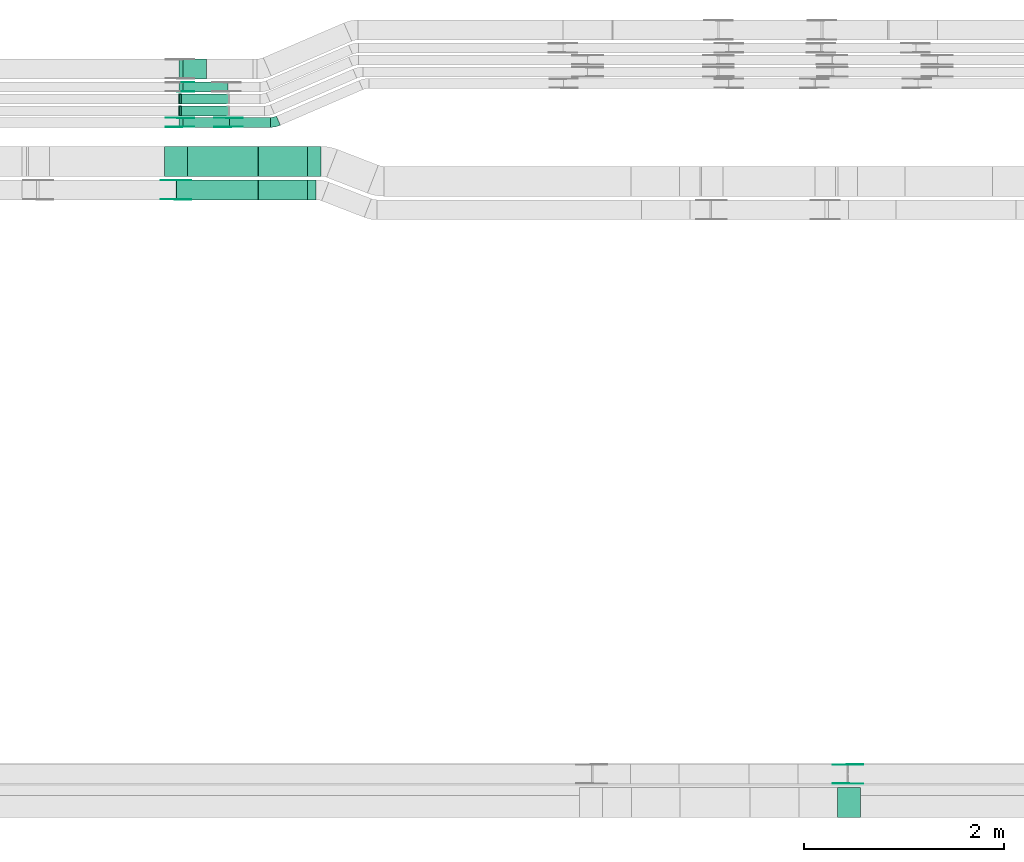
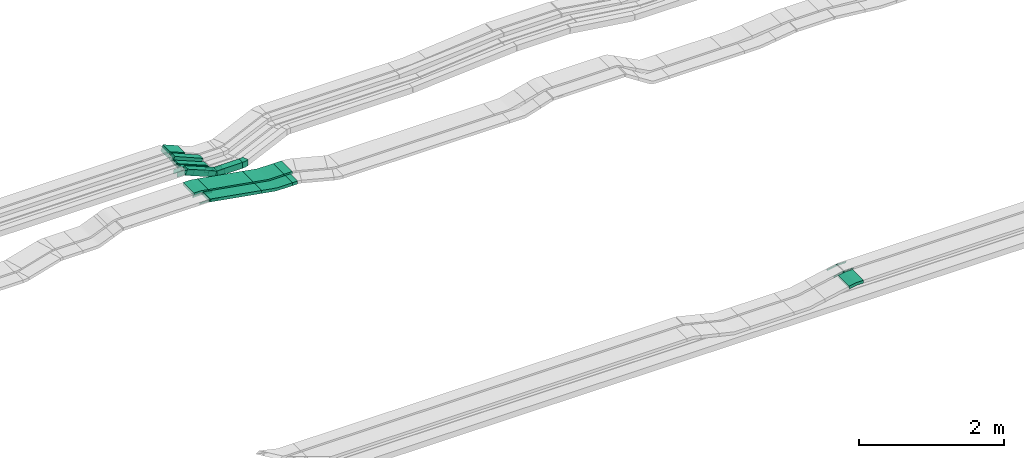
# One storey, part 15 of 28: 25 flow fittings, 10 flow segments.
"""IFC2X3 building model written with IfcOpenShell, lengths in millimetres."""

from ifc_helpers import new_model, entity, si_unit, converted_unit, derived_unit, direction, frame, frame_2d, origin, origin_2d_with_axis, place, context, subcontext, project, spatial, polyline, circle_curve, parameter, trimmed, segment, composite_curve, rectangle, outline, extrude, faceted_brep, source, transform, mapped, material, type_object, type_shapes, element, save


model = new_model("IFC2X3")

# Units and contexts
model_context = context("Model", 3, precision=0.01, world=origin(), true_north=direction((6.12303176911189e-17, 1.0)))
body_context = subcontext(model_context, "Body", "Model", "MODEL_VIEW")
ifc_project = project(units=[si_unit("LENGTHUNIT", "METRE", prefix="MILLI"), si_unit("AREAUNIT", "SQUARE_METRE"), si_unit("VOLUMEUNIT", "CUBIC_METRE"), converted_unit("PLANEANGLEUNIT", "DEGREE", entity("IfcRatioMeasure", 0.0174532925199433), si_unit("PLANEANGLEUNIT", "RADIAN"), dimensions=[0, 0, 0, 0, 0, 0, 0]), si_unit("MASSUNIT", "GRAM", prefix="KILO"), derived_unit("MASSDENSITYUNIT", [(si_unit("MASSUNIT", "GRAM", prefix="KILO"), 1), (si_unit("LENGTHUNIT", "METRE"), -3)]), derived_unit("MOMENTOFINERTIAUNIT", [(si_unit("LENGTHUNIT", "METRE"), 4)]), si_unit("TIMEUNIT", "SECOND"), si_unit("FREQUENCYUNIT", "HERTZ"), si_unit("THERMODYNAMICTEMPERATUREUNIT", "DEGREE_CELSIUS"), derived_unit("THERMALTRANSMITTANCEUNIT", [(si_unit("MASSUNIT", "GRAM", prefix="KILO"), 1), (si_unit("THERMODYNAMICTEMPERATUREUNIT", "KELVIN"), -1), (si_unit("TIMEUNIT", "SECOND"), -3)]), derived_unit("VOLUMETRICFLOWRATEUNIT", [(si_unit("LENGTHUNIT", "METRE"), 3), (si_unit("TIMEUNIT", "SECOND"), -1)]), derived_unit("MASSFLOWRATEUNIT", [(si_unit("MASSUNIT", "GRAM", prefix="KILO"), 1), (si_unit("TIMEUNIT", "SECOND"), -1)]), derived_unit("ROTATIONALFREQUENCYUNIT", [(si_unit("TIMEUNIT", "SECOND"), -1)]), si_unit("ELECTRICCURRENTUNIT", "AMPERE"), si_unit("ELECTRICVOLTAGEUNIT", "VOLT"), si_unit("POWERUNIT", "WATT"), si_unit("FORCEUNIT", "NEWTON", prefix="KILO"), si_unit("ILLUMINANCEUNIT", "LUX"), si_unit("LUMINOUSFLUXUNIT", "LUMEN"), si_unit("LUMINOUSINTENSITYUNIT", "CANDELA"), derived_unit("USERDEFINED", [(si_unit("MASSUNIT", "GRAM", prefix="KILO"), -1), (si_unit("LENGTHUNIT", "METRE"), -2), (si_unit("TIMEUNIT", "SECOND"), 3), (si_unit("LUMINOUSFLUXUNIT", "LUMEN"), 1)]), derived_unit("LINEARVELOCITYUNIT", [(si_unit("LENGTHUNIT", "METRE"), 1), (si_unit("TIMEUNIT", "SECOND"), -1)]), si_unit("PRESSUREUNIT", "PASCAL"), derived_unit("USERDEFINED", [(si_unit("LENGTHUNIT", "METRE"), -2), (si_unit("MASSUNIT", "GRAM", prefix="KILO"), 1), (si_unit("TIMEUNIT", "SECOND"), -2)]), derived_unit("LINEARFORCEUNIT", [(si_unit("MASSUNIT", "GRAM", prefix="KILO"), 1), (si_unit("LENGTHUNIT", "METRE"), 1), (si_unit("TIMEUNIT", "SECOND"), -2), (si_unit("LENGTHUNIT", "METRE"), -1)]), derived_unit("PLANARFORCEUNIT", [(si_unit("MASSUNIT", "GRAM", prefix="KILO"), 1), (si_unit("LENGTHUNIT", "METRE"), 1), (si_unit("TIMEUNIT", "SECOND"), -2), (si_unit("LENGTHUNIT", "METRE"), -2)])], contexts=[model_context])

# Site, building, storey
site_placement = place(None, origin())
site = spatial("IfcSite", under=ifc_project, at=site_placement, CompositionType="ELEMENT")
building_placement = place(site_placement, origin())
building = spatial("IfcBuilding", under=site, at=building_placement, CompositionType="ELEMENT")
storey_placement = place(building_placement, frame((0.0, 0.0, 15900.0)))
storey = spatial("IfcBuildingStorey", under=building, at=storey_placement, CompositionType="ELEMENT", Elevation=15900.0)

# Flow segments
cable_carrier_segment_type = type_object("IfcCableCarrierSegmentType", PredefinedType="CABLETRAYSEGMENT")
flow_segment_1_placement = place(storey_placement, frame((45693.95, 15124.99, 2634.95)))
element("IfcFlowSegment", 1, at=flow_segment_1_placement, inside=storey, type_object=cable_carrier_segment_type, context=body_context, shape_type="SweptSolid", body=[
    extrude(rectangle(XDim=406.031422459047, YDim=99.9999999999989, at=origin_2d_with_axis()), frame((203.02, 50.0, 0.0)), (0.0, 0.0, 1.0), 99.9999999999989),
])
flow_segment_2_placement = place(storey_placement, frame((45186.78, 15124.99, 2643.12)))
element("IfcFlowSegment", 2, at=flow_segment_2_placement, inside=storey, type_object=cable_carrier_segment_type, context=body_context, shape_type="SweptSolid", body=[
    extrude(rectangle(XDim=99.9999999999964, YDim=99.9999999999989, at=origin_2d_with_axis()), frame((18.98, 50.0, 237.42), z_axis=(0.92511308529448, 0.0, -0.37969168994979), x_axis=(0.37969168994979, 0.0, 0.92511308529448)), (0.0, 0.0, 1.0), 503.461377096309),
])
flow_segment_3_placement = place(storey_placement, frame((45191.31, 15239.46, 2642.86)))
element("IfcFlowSegment", 3, at=flow_segment_3_placement, inside=storey, type_object=cable_carrier_segment_type, context=body_context, shape_type="SweptSolid", body=[
    extrude(rectangle(XDim=50.0000000000019, YDim=99.9999999999989, at=origin_2d_with_axis()), frame((9.49, 50.0, 216.4), z_axis=(0.925113085294563, 0.0, -0.379691689949589), x_axis=(0.379691689949589, 0.0, 0.925113085294563)), (0.0, 0.0, 1.0), 509.012241763836),
])
flow_segment_4_placement = place(storey_placement, frame((45191.31, 15359.46, 2642.86)))
element("IfcFlowSegment", 4, at=flow_segment_4_placement, inside=storey, type_object=cable_carrier_segment_type, context=body_context, shape_type="SweptSolid", body=[
    extrude(rectangle(XDim=50.0000000000092, YDim=99.9999999999989, at=origin_2d_with_axis()), frame((9.49, 50.0, 216.4), z_axis=(0.925113085294515, 0.0, -0.379691689949707), x_axis=(0.379691689949707, 0.0, 0.925113085294515)), (0.0, 0.0, 1.0), 509.012241762945),
])
flow_segment_5_placement = place(storey_placement, frame((45186.49, 15479.99, 2643.67)))
element("IfcFlowSegment", 5, at=flow_segment_5_placement, inside=storey, type_object=cable_carrier_segment_type, context=body_context, shape_type="SweptSolid", body=[
    extrude(rectangle(XDim=99.9999999999968, YDim=99.9999999999989, at=origin_2d_with_axis()), frame((19.55, 50.0, 236.64), z_axis=(0.92041129975061, 0.0, -0.390951453880648), x_axis=(0.390951453880648, 0.0, 0.92041129975061)), (0.0, 0.0, 1.0), 487.586158263763),
])
flow_segment_6_placement = place(storey_placement, frame((45186.66, 15609.99, 2735.0)))
element("IfcFlowSegment", 6, at=flow_segment_6_placement, inside=storey, type_object=cable_carrier_segment_type, context=body_context, shape_type="SweptSolid", body=[
    extrude(rectangle(XDim=99.9999999999999, YDim=199.999999999998, at=origin_2d_with_axis()), frame((19.23, 100.0, 145.46), z_axis=(0.923076923076912, 0.0, -0.384615384615411), x_axis=(0.384615384615411, 0.0, 0.923076923076912)), (0.0, 0.0, 1.0), 258.199999999951),
])
flow_segment_7_placement = place(storey_placement, frame((46475.24, 14635.03, 2650.0)))
element("IfcFlowSegment", 7, at=flow_segment_7_placement, inside=storey, type_object=cable_carrier_segment_type, context=body_context, shape_type="SweptSolid", body=[
    extrude(rectangle(XDim=133.135877151261, YDim=300.000000000001, at=origin_2d_with_axis()), frame((66.57, 150.0, 0.0), z_axis=(0.0, 0.0, 1.0), x_axis=(-1.0, 0.0, 0.0)), (0.0, 0.0, 1.0), 50.0000000000016),
])
flow_segment_8_placement = place(storey_placement, frame((46475.24, 14400.03, 2650.0)))
element("IfcFlowSegment", 8, at=flow_segment_8_placement, inside=storey, type_object=cable_carrier_segment_type, context=body_context, shape_type="SweptSolid", body=[
    extrude(rectangle(XDim=82.4973887325516, YDim=200.000000000002, at=origin_2d_with_axis()), frame((41.25, 100.0, 0.0), z_axis=(0.0, 0.0, 1.0), x_axis=(-1.0, 0.0, 0.0)), (0.0, 0.0, 1.0), 50.0000000000038),
])
flow_segment_9_placement = place(storey_placement, frame((45154.32, 14400.03, 2692.89)))
element("IfcFlowSegment", 9, at=flow_segment_9_placement, inside=storey, type_object=cable_carrier_segment_type, context=body_context, shape_type="SweptSolid", body=[
    extrude(rectangle(XDim=49.9999999999991, YDim=199.999999999998, at=origin_2d_with_axis()), frame((4.26, 100.0, 166.52), z_axis=(0.985391054853274, 0.0, -0.170306984634076), x_axis=(0.170306984634076, 0.0, 0.985391054853274)), (0.0, 0.0, 1.0), 833.091034374861),
])
flow_segment_10_placement = place(storey_placement, frame((45262.92, 14635.03, 2692.89)))
element("IfcFlowSegment", 10, at=flow_segment_10_placement, inside=storey, type_object=cable_carrier_segment_type, context=body_context, shape_type="SweptSolid", body=[
    extrude(rectangle(XDim=49.9999999999991, YDim=300.000000000001, at=origin_2d_with_axis()), frame((4.26, 150.0, 147.75), z_axis=(0.985391054853274, 0.0, -0.170306984634076), x_axis=(0.170306984634076, 0.0, 0.985391054853274)), (0.0, 0.0, 1.0), 722.876962824568),
])

# Flow fittings
ifc_material_1 = material()
cable_carrier_fitting_type_1 = type_object("IfcCableCarrierFittingType", PredefinedType="NOTDEFINED", material=ifc_material_1)
shared_shape_1 = source(origin(), body_context, "Body", "Brep", [
    faceted_brep([(-9.86, 25.0, 50.0), (-9.86, 25.0, -50.0), (-9.86, -25.0, -50.0), (-9.86, -25.0, -47.46), (-9.86, 22.46, -47.46), (-9.86, 22.46, 47.46), (-9.86, -25.0, 47.46), (-9.86, -25.0, 50.0), (-0.37, 26.87, 50.0), (18.62, -19.38, 50.0), (18.62, -19.38, 47.46), (0.6, 24.52, 47.46), (0.6, 24.52, -47.46), (18.62, -19.38, -47.46), (18.62, -19.38, -50.0), (-0.37, 26.87, -50.0), (-4.93, 25.0, 50.0), (-4.93, 25.0, -50.0), (4.93, -25.0, -50.0), (4.93, -25.0, -47.46), (-4.43, 22.46, -47.46), (-4.43, 22.46, 47.46), (4.93, -25.0, 47.46), (4.93, -25.0, 50.0)], [[[0, 1, 2, 3, 4, 5, 6, 7]], [[8, 9, 10, 11, 12, 13, 14, 15]], [[1, 0, 16, 17]], [[2, 1, 17, 15, 14, 18]], [[3, 2, 18, 19]], [[4, 3, 19, 13, 12, 20]], [[5, 4, 20, 21]], [[6, 5, 21, 11, 10, 22]], [[7, 6, 22, 23]], [[0, 7, 23, 9, 8, 16]], [[17, 16, 8, 15]], [[19, 18, 14, 13]], [[21, 20, 12, 11]], [[23, 22, 10, 9]]]),
])
type_shapes(cable_carrier_fitting_type_1, [shared_shape_1])
for number, where, z_axis, x_axis in (
    (11, (45191.68, 15289.46, 2863.0), (0.0, 1.0, 0.0), (1.0, 0.0, 0.0)),
    (12, (45191.68, 15409.46, 2863.0), (0.0, 1.0, 0.0), (1.0, 0.0, 0.0)),
):
    element("IfcFlowFitting", number, at=place(storey_placement, frame(where, z_axis=z_axis, x_axis=x_axis)), inside=storey, type_object=cable_carrier_fitting_type_1, material=ifc_material_1, context=body_context, shape_type="MappedRepresentation", body=[
        mapped(shared_shape_1, transform((0.0, 0.0, 0.0), scale=1.0)),
    ])
ifc_material_2 = material(Name="G")
cable_carrier_fitting_type_2 = type_object("IfcCableCarrierFittingType", PredefinedType="NOTDEFINED", material=ifc_material_2)
shared_shape_2 = source(origin(), body_context, "Body", "SweptSolid", [
    extrude(outline(composite_curve([segment(trimmed(circle_curve(frame_2d((-44.59, 0.0), x_axis=(1.0, 0.0)), 12.5), [parameter(90.0000000000007)], [parameter(270.0)], True, "PARAMETER"), True, "CONTINUOUS"), segment(polyline([(-44.59, -12.5), (-33.09, -12.5)]), True, "CONTINUOUS"), segment(polyline([(-33.09, -12.5), (-31.23, -14.5)]), True, "CONTINUOUS"), segment(polyline([(-31.23, -14.5), (108.91, -14.5)]), True, "CONTINUOUS"), segment(polyline([(108.91, -14.5), (108.91, 14.5)]), True, "CONTINUOUS"), segment(polyline([(108.91, 14.5), (-31.23, 14.5)]), True, "CONTINUOUS"), segment(polyline([(-31.23, 14.5), (-33.09, 12.5)]), True, "CONTINUOUS"), segment(polyline([(-33.09, 12.5), (-44.59, 12.5)]), True, "CONTINUOUS")], self_intersect=False)), frame((44.59, 0.0, 0.0), z_axis=(0.0, 0.0, -1.0), x_axis=(1.0, 0.0, 0.0)), (0.0, 0.0, -1.0), 2.0),
])
type_shapes(cable_carrier_fitting_type_2, [shared_shape_2])
flow_fitting_1_placement = place(storey_placement, frame((51885.49, 8745.61, 2845.0), z_axis=(0.0, 1.0, 0.0), x_axis=(1.0, 0.0, 0.0)))
element("IfcFlowFitting", 13, at=flow_fitting_1_placement, inside=storey, type_object=cable_carrier_fitting_type_2, material=ifc_material_2, context=body_context, shape_type="MappedRepresentation", body=[
    mapped(shared_shape_2, transform((0.0, 0.0, 0.0), scale=1.0)),
])
cable_carrier_fitting_type_3 = type_object("IfcCableCarrierFittingType", PredefinedType="NOTDEFINED", material=ifc_material_2)
type_shapes(cable_carrier_fitting_type_3, [shared_shape_2])
flow_fitting_2_placement = place(storey_placement, frame((51885.49, 8556.69, 2845.0), z_axis=(0.0, -1.0, 0.0), x_axis=(-0.980265659659694, 0.0, -0.197684689573939)))
element("IfcFlowFitting", 14, at=flow_fitting_2_placement, inside=storey, type_object=cable_carrier_fitting_type_3, material=ifc_material_2, context=body_context, shape_type="MappedRepresentation", body=[
    mapped(shared_shape_2, transform((0.0, 0.0, 0.0), scale=1.0)),
])
flow_fitting_3_placement = place(storey_placement, frame((45155.14, 14595.49, 2860.0), z_axis=(0.0, 1.0, 0.0), x_axis=(0.985391054853256, 0.0, -0.170306984634182)))
element("IfcFlowFitting", 15, at=flow_fitting_3_placement, inside=storey, type_object=cable_carrier_fitting_type_2, material=ifc_material_2, context=body_context, shape_type="MappedRepresentation", body=[
    mapped(shared_shape_2, transform((0.0, 0.0, 0.0), scale=1.0)),
])
flow_fitting_4_placement = place(storey_placement, frame((45155.14, 14406.57, 2860.0), z_axis=(0.0, -1.0, 0.0), x_axis=(-1.0, 0.0, 0.0)))
element("IfcFlowFitting", 16, at=flow_fitting_4_placement, inside=storey, type_object=cable_carrier_fitting_type_3, material=ifc_material_2, context=body_context, shape_type="MappedRepresentation", body=[
    mapped(shared_shape_2, transform((0.0, 0.0, 0.0), scale=1.0)),
])
cable_carrier_fitting_type_4 = type_object("IfcCableCarrierFittingType", PredefinedType="NOTDEFINED", material=ifc_material_2)
shared_shape_3 = source(origin(), body_context, "Body", "SweptSolid", [
    extrude(outline(composite_curve([segment(trimmed(circle_curve(frame_2d((-44.59, 0.0), x_axis=(1.0, 0.0)), 12.5), [parameter(90.0000000000007)], [parameter(270.0)], True, "PARAMETER"), True, "CONTINUOUS"), segment(polyline([(-44.59, -12.5), (-33.09, -12.5)]), True, "CONTINUOUS"), segment(polyline([(-33.09, -12.5), (-31.23, -14.5)]), True, "CONTINUOUS"), segment(polyline([(-31.23, -14.5), (108.91, -14.5)]), True, "CONTINUOUS"), segment(polyline([(108.91, -14.5), (108.91, 14.5)]), True, "CONTINUOUS"), segment(polyline([(108.91, 14.5), (-31.23, 14.5)]), True, "CONTINUOUS"), segment(polyline([(-31.23, 14.5), (-33.09, 12.5)]), True, "CONTINUOUS"), segment(polyline([(-33.09, 12.5), (-44.59, 12.5)]), True, "CONTINUOUS")], self_intersect=False)), frame((44.59, 0.0, 0.0)), (0.0, 0.0, 1.0), 2.0),
])
type_shapes(cable_carrier_fitting_type_4, [shared_shape_3])
flow_fitting_5_placement = place(storey_placement, frame((51885.49, 8554.69, 2845.0), z_axis=(0.0, -1.0, 0.0), x_axis=(1.0, 0.0, 0.0)))
element("IfcFlowFitting", 17, at=flow_fitting_5_placement, inside=storey, type_object=cable_carrier_fitting_type_4, material=ifc_material_2, context=body_context, shape_type="MappedRepresentation", body=[
    mapped(shared_shape_3, transform((0.0, 0.0, 0.0), scale=1.0)),
])
cable_carrier_fitting_type_5 = type_object("IfcCableCarrierFittingType", PredefinedType="NOTDEFINED", material=ifc_material_2)
type_shapes(cable_carrier_fitting_type_5, [shared_shape_3])
flow_fitting_6_placement = place(storey_placement, frame((51885.49, 8743.61, 2845.0), z_axis=(0.0, 1.0, 0.0), x_axis=(-0.980265659659694, 0.0, -0.197684689573939)))
element("IfcFlowFitting", 18, at=flow_fitting_6_placement, inside=storey, type_object=cable_carrier_fitting_type_5, material=ifc_material_2, context=body_context, shape_type="MappedRepresentation", body=[
    mapped(shared_shape_3, transform((0.0, 0.0, 0.0), scale=1.0)),
])
flow_fitting_7_placement = place(storey_placement, frame((45155.14, 14404.57, 2860.0), z_axis=(0.0, -1.0, 0.0), x_axis=(0.985391054853256, 0.0, -0.170306984634182)))
element("IfcFlowFitting", 19, at=flow_fitting_7_placement, inside=storey, type_object=cable_carrier_fitting_type_4, material=ifc_material_2, context=body_context, shape_type="MappedRepresentation", body=[
    mapped(shared_shape_3, transform((0.0, 0.0, 0.0), scale=1.0)),
])
flow_fitting_8_placement = place(storey_placement, frame((45155.14, 14593.49, 2860.0), z_axis=(0.0, 1.0, 0.0), x_axis=(-1.0, 0.0, 0.0)))
element("IfcFlowFitting", 20, at=flow_fitting_8_placement, inside=storey, type_object=cable_carrier_fitting_type_5, material=ifc_material_2, context=body_context, shape_type="MappedRepresentation", body=[
    mapped(shared_shape_3, transform((0.0, 0.0, 0.0), scale=1.0)),
])
cable_carrier_fitting_type_6 = type_object("IfcCableCarrierFittingType", Name="470_DKC_S5_CD 90 external vertical angle:-", PredefinedType="NOTDEFINED", material=ifc_material_1)
shared_shape_4 = source(origin(), body_context, "Body", "SweptSolid", [
    extrude(outline(composite_curve([segment(polyline([(-113.01, -31.43), (-15.83, -31.43)]), True, "CONTINUOUS"), segment(trimmed(circle_curve(frame_2d((-15.83, 158.57), x_axis=(0.0, -1.0)), 189.999999999999), [parameter(0.0)], [parameter(11.4015985350617)], True, "PARAMETER"), True, "CONTINUOUS"), segment(polyline([(21.73, -27.68), (116.99, -8.47)]), True, "CONTINUOUS"), segment(polyline([(116.99, -8.47), (107.11, 40.54)]), True, "CONTINUOUS"), segment(polyline([(107.11, 40.54), (11.85, 21.33)]), True, "CONTINUOUS"), segment(trimmed(circle_curve(frame_2d((-15.83, 158.57), x_axis=(0.0, -1.0)), 139.999999999999), [parameter(0.0)], [parameter(11.4015985350617)], True, "PARAMETER"), False, "CONTINUOUS"), segment(polyline([(-15.83, 18.57), (-113.01, 18.57)]), True, "CONTINUOUS"), segment(polyline([(-113.01, 18.57), (-113.01, -31.43)]), True, "CONTINUOUS")], self_intersect=False)), frame((-0.64, 6.43, -150.0)), (0.0, 0.0, 1.0), 300.0),
])
type_shapes(cable_carrier_fitting_type_6, [shared_shape_4])
flow_fitting_9_placement = place(storey_placement, frame((51895.29, 8365.15, 2845.0), z_axis=(0.0, 1.0, 0.0), x_axis=(0.980265659659693, 0.0, 0.197684689573945)))
element("IfcFlowFitting", 21, at=flow_fitting_9_placement, inside=storey, type_object=cable_carrier_fitting_type_6, material=ifc_material_1, Name="470_DKC_S5_CD 90 external vertical angle:-", ObjectType="470_DKC_S5_CD 90 external vertical angle:-", context=body_context, shape_type="MappedRepresentation", body=[
    mapped(shared_shape_4, transform((0.0, 0.0, 0.0), scale=1.0)),
])
cable_carrier_fitting_type_7 = type_object("IfcCableCarrierFittingType", PredefinedType="NOTDEFINED", material=ifc_material_2)
shared_shape_5 = source(origin(), body_context, "Body", "SweptSolid", [
    extrude(outline(composite_curve([segment(trimmed(circle_curve(frame_2d((-41.47, 0.0), x_axis=(1.0, 0.0)), 25.0), [parameter(90.0000000000007)], [parameter(270.0)], True, "PARAMETER"), True, "CONTINUOUS"), segment(polyline([(-41.47, -25.0), (-29.97, -25.0)]), True, "CONTINUOUS"), segment(polyline([(-29.97, -25.0), (-28.1, -38.5)]), True, "CONTINUOUS"), segment(polyline([(-28.1, -38.5), (99.53, -38.5)]), True, "CONTINUOUS"), segment(polyline([(99.53, -38.5), (99.53, 38.5)]), True, "CONTINUOUS"), segment(polyline([(99.53, 38.5), (-28.1, 38.5)]), True, "CONTINUOUS"), segment(polyline([(-28.1, 38.5), (-29.97, 25.0)]), True, "CONTINUOUS"), segment(polyline([(-29.97, 25.0), (-41.47, 25.0)]), True, "CONTINUOUS")], self_intersect=False)), frame((41.47, 0.0, 0.0), z_axis=(0.0, 0.0, -1.0), x_axis=(1.0, 0.0, 0.0)), (0.0, 0.0, -1.0), 2.0),
])
type_shapes(cable_carrier_fitting_type_7, [shared_shape_5])
for number, where, z_axis, x_axis in (
    (22, (45195.0, 15575.45, 2885.0), (0.0, 1.0, 0.0), (0.920411299750602, 0.0, -0.390951453880668)),
    (23, (45194.98, 15129.53, 2884.96), (0.0, -1.0, 0.0), (-1.0, 0.0, 0.0)),
):
    element("IfcFlowFitting", number, at=place(storey_placement, frame(where, z_axis=z_axis, x_axis=x_axis)), inside=storey, type_object=cable_carrier_fitting_type_7, material=ifc_material_2, context=body_context, shape_type="MappedRepresentation", body=[
        mapped(shared_shape_5, transform((0.0, 0.0, 0.0), scale=1.0)),
    ])
cable_carrier_fitting_type_8 = type_object("IfcCableCarrierFittingType", PredefinedType="NOTDEFINED", material=ifc_material_2)
type_shapes(cable_carrier_fitting_type_8, [shared_shape_5])
flow_fitting_10_placement = place(storey_placement, frame((45194.98, 15218.45, 2884.96), z_axis=(0.0, 1.0, 0.0), x_axis=(0.925113085294536, 0.0, -0.379691689949654)))
element("IfcFlowFitting", 24, at=flow_fitting_10_placement, inside=storey, type_object=cable_carrier_fitting_type_8, material=ifc_material_2, context=body_context, shape_type="MappedRepresentation", body=[
    mapped(shared_shape_5, transform((0.0, 0.0, 0.0), scale=1.0)),
])
flow_fitting_11_placement = place(storey_placement, frame((45682.3, 15220.45, 2684.95), z_axis=(0.0, 1.0, 0.0), x_axis=(-0.925113085296403, 0.0, 0.379691689945105)))
element("IfcFlowFitting", 25, at=flow_fitting_11_placement, inside=storey, type_object=cable_carrier_fitting_type_7, material=ifc_material_2, context=body_context, shape_type="MappedRepresentation", body=[
    mapped(shared_shape_5, transform((0.0, 0.0, 0.0), scale=1.0)),
])
flow_fitting_12_placement = place(storey_placement, frame((45682.3, 15131.53, 2684.95), z_axis=(0.0, -1.0, 0.0), x_axis=(1.0, 0.0, 0.0)))
element("IfcFlowFitting", 26, at=flow_fitting_12_placement, inside=storey, type_object=cable_carrier_fitting_type_8, material=ifc_material_2, context=body_context, shape_type="MappedRepresentation", body=[
    mapped(shared_shape_5, transform((0.0, 0.0, 0.0), scale=1.0)),
])
cable_carrier_fitting_type_9 = type_object("IfcCableCarrierFittingType", PredefinedType="NOTDEFINED", material=ifc_material_2)
shared_shape_6 = source(origin(), body_context, "Body", "SweptSolid", [
    extrude(outline(composite_curve([segment(trimmed(circle_curve(frame_2d((-41.47, 0.0), x_axis=(1.0, 0.0)), 25.0), [parameter(90.0000000000007)], [parameter(270.0)], True, "PARAMETER"), True, "CONTINUOUS"), segment(polyline([(-41.47, -25.0), (-29.97, -25.0)]), True, "CONTINUOUS"), segment(polyline([(-29.97, -25.0), (-28.1, -38.5)]), True, "CONTINUOUS"), segment(polyline([(-28.1, -38.5), (99.53, -38.5)]), True, "CONTINUOUS"), segment(polyline([(99.53, -38.5), (99.53, 38.5)]), True, "CONTINUOUS"), segment(polyline([(99.53, 38.5), (-28.1, 38.5)]), True, "CONTINUOUS"), segment(polyline([(-28.1, 38.5), (-29.97, 25.0)]), True, "CONTINUOUS"), segment(polyline([(-29.97, 25.0), (-41.47, 25.0)]), True, "CONTINUOUS")], self_intersect=False)), frame((41.47, 0.0, 0.0)), (0.0, 0.0, 1.0), 2.0),
])
type_shapes(cable_carrier_fitting_type_9, [shared_shape_6])
for number, where, z_axis, x_axis in (
    (27, (45195.0, 15484.53, 2885.0), (0.0, -1.0, 0.0), (0.920411299750602, 0.0, -0.390951453880668)),
    (28, (45194.98, 15220.45, 2884.96), (0.0, 1.0, 0.0), (-1.0, 0.0, 0.0)),
):
    element("IfcFlowFitting", number, at=place(storey_placement, frame(where, z_axis=z_axis, x_axis=x_axis)), inside=storey, type_object=cable_carrier_fitting_type_9, material=ifc_material_2, context=body_context, shape_type="MappedRepresentation", body=[
        mapped(shared_shape_6, transform((0.0, 0.0, 0.0), scale=1.0)),
    ])
cable_carrier_fitting_type_10 = type_object("IfcCableCarrierFittingType", PredefinedType="NOTDEFINED", material=ifc_material_2)
type_shapes(cable_carrier_fitting_type_10, [shared_shape_6])
flow_fitting_13_placement = place(storey_placement, frame((45194.98, 15131.53, 2884.96), z_axis=(0.0, -1.0, 0.0), x_axis=(0.925113085294536, 0.0, -0.379691689949654)))
element("IfcFlowFitting", 29, at=flow_fitting_13_placement, inside=storey, type_object=cable_carrier_fitting_type_10, material=ifc_material_2, context=body_context, shape_type="MappedRepresentation", body=[
    mapped(shared_shape_6, transform((0.0, 0.0, 0.0), scale=1.0)),
])
flow_fitting_14_placement = place(storey_placement, frame((45682.3, 15129.53, 2684.95), z_axis=(0.0, -1.0, 0.0), x_axis=(-0.925113085296403, 0.0, 0.379691689945105)))
element("IfcFlowFitting", 30, at=flow_fitting_14_placement, inside=storey, type_object=cable_carrier_fitting_type_9, material=ifc_material_2, context=body_context, shape_type="MappedRepresentation", body=[
    mapped(shared_shape_6, transform((0.0, 0.0, 0.0), scale=1.0)),
])
flow_fitting_15_placement = place(storey_placement, frame((45682.3, 15218.45, 2684.95), z_axis=(0.0, 1.0, 0.0), x_axis=(1.0, 0.0, 0.0)))
element("IfcFlowFitting", 31, at=flow_fitting_15_placement, inside=storey, type_object=cable_carrier_fitting_type_10, material=ifc_material_2, context=body_context, shape_type="MappedRepresentation", body=[
    mapped(shared_shape_6, transform((0.0, 0.0, 0.0), scale=1.0)),
])
cable_carrier_fitting_type_11 = type_object("IfcCableCarrierFittingType", Name="470_DKC_S5_CS 90 internal vertical angle:-", PredefinedType="NOTDEFINED", material=ifc_material_1)
shared_shape_7 = source(origin(), body_context, "Body", "SweptSolid", [
    extrude(outline(composite_curve([segment(polyline([(-248.74, -36.14), (-11.05, -36.14)]), True, "CONTINUOUS"), segment(trimmed(circle_curve(frame_2d((-11.05, 128.86), x_axis=(0.0, -1.0)), 164.999999999999), [parameter(0.0)], [parameter(9.80566826552612)], True, "PARAMETER"), True, "CONTINUOUS"), segment(polyline([(17.05, -33.73), (251.26, 6.75)]), True, "CONTINUOUS"), segment(polyline([(251.26, 6.75), (242.75, 56.02)]), True, "CONTINUOUS"), segment(polyline([(242.75, 56.02), (8.53, 15.54)]), True, "CONTINUOUS"), segment(trimmed(circle_curve(frame_2d((-11.05, 128.86), x_axis=(0.0, -1.0)), 114.999999999999), [parameter(0.0)], [parameter(9.80566826552612)], True, "PARAMETER"), False, "CONTINUOUS"), segment(polyline([(-11.05, 13.86), (-248.74, 13.86)]), True, "CONTINUOUS"), segment(polyline([(-248.74, 13.86), (-248.74, -36.14)]), True, "CONTINUOUS")], self_intersect=False)), frame((-0.96, 11.14, -100.0)), (0.0, 0.0, 1.0), 200.0),
])
type_shapes(cable_carrier_fitting_type_11, [shared_shape_7])
flow_fitting_16_placement = place(storey_placement, frame((46225.54, 14500.03, 2675.0), z_axis=(0.0, 1.0, 0.0), x_axis=(-1.0, 0.0, 0.0)))
element("IfcFlowFitting", 32, at=flow_fitting_16_placement, inside=storey, type_object=cable_carrier_fitting_type_11, material=ifc_material_1, Name="470_DKC_S5_CS 90 internal vertical angle:-", ObjectType="470_DKC_S5_CS 90 internal vertical angle:-", context=body_context, shape_type="MappedRepresentation", body=[
    mapped(shared_shape_7, transform((0.0, 0.0, 0.0), scale=1.0)),
])
cable_carrier_fitting_type_12 = type_object("IfcCableCarrierFittingType", Name="470_DKC_S5_CS 90 internal vertical angle:-", PredefinedType="NOTDEFINED", material=ifc_material_1)
shared_shape_8 = source(origin(), body_context, "Body", "SweptSolid", [
    extrude(outline(composite_curve([segment(polyline([(-248.74, -36.14), (-11.05, -36.14)]), True, "CONTINUOUS"), segment(trimmed(circle_curve(frame_2d((-11.05, 128.86), x_axis=(0.0, -1.0)), 164.999999999999), [parameter(0.0)], [parameter(9.80566826552648)], True, "PARAMETER"), True, "CONTINUOUS"), segment(polyline([(17.05, -33.73), (251.26, 6.75)]), True, "CONTINUOUS"), segment(polyline([(251.26, 6.75), (242.75, 56.02)]), True, "CONTINUOUS"), segment(polyline([(242.75, 56.02), (8.53, 15.54)]), True, "CONTINUOUS"), segment(trimmed(circle_curve(frame_2d((-11.05, 128.86), x_axis=(0.0, -1.0)), 114.999999999999), [parameter(0.0)], [parameter(9.80566826552648)], True, "PARAMETER"), False, "CONTINUOUS"), segment(polyline([(-11.05, 13.86), (-248.74, 13.86)]), True, "CONTINUOUS"), segment(polyline([(-248.74, 13.86), (-248.74, -36.14)]), True, "CONTINUOUS")], self_intersect=False)), frame((-0.96, 11.14, -150.0)), (0.0, 0.0, 1.0), 300.0),
])
type_shapes(cable_carrier_fitting_type_12, [shared_shape_8])
flow_fitting_17_placement = place(storey_placement, frame((46225.54, 14785.03, 2675.0), z_axis=(0.0, 1.0, 0.0), x_axis=(-1.0, 0.0, 0.0)))
element("IfcFlowFitting", 33, at=flow_fitting_17_placement, inside=storey, type_object=cable_carrier_fitting_type_12, material=ifc_material_1, Name="470_DKC_S5_CS 90 internal vertical angle:-", ObjectType="470_DKC_S5_CS 90 internal vertical angle:-", context=body_context, shape_type="MappedRepresentation", body=[
    mapped(shared_shape_8, transform((0.0, 0.0, 0.0), scale=1.0)),
])
cable_carrier_fitting_type_13 = type_object("IfcCableCarrierFittingType", Name="470_DKC_S5_CD 90 external vertical angle:-", PredefinedType="NOTDEFINED", material=ifc_material_1)
shared_shape_9 = source(origin(), body_context, "Body", "SweptSolid", [
    extrude(outline(composite_curve([segment(polyline([(-113.23, -30.44), (-13.69, -30.44)]), True, "CONTINUOUS"), segment(trimmed(circle_curve(frame_2d((-13.69, 159.56), x_axis=(0.0, -1.0)), 189.999999999999), [parameter(0.0)], [parameter(9.80566826552648)], True, "PARAMETER"), True, "CONTINUOUS"), segment(polyline([(18.67, -27.67), (116.77, -10.71)]), True, "CONTINUOUS"), segment(polyline([(116.77, -10.71), (108.25, 38.56)]), True, "CONTINUOUS"), segment(polyline([(108.25, 38.56), (10.16, 21.6)]), True, "CONTINUOUS"), segment(trimmed(circle_curve(frame_2d((-13.69, 159.56), x_axis=(0.0, -1.0)), 139.999999999999), [parameter(0.0)], [parameter(9.80566826552648)], True, "PARAMETER"), False, "CONTINUOUS"), segment(polyline([(-13.69, 19.56), (-113.23, 19.56)]), True, "CONTINUOUS"), segment(polyline([(-113.23, 19.56), (-113.23, -30.44)]), True, "CONTINUOUS")], self_intersect=False)), frame((-0.47, 5.44, -150.0)), (0.0, 0.0, 1.0), 300.0),
])
type_shapes(cable_carrier_fitting_type_13, [shared_shape_9])
flow_fitting_18_placement = place(storey_placement, frame((45155.14, 14785.03, 2860.0), z_axis=(0.0, 1.0, 0.0), x_axis=(1.0, 0.0, 0.0)))
element("IfcFlowFitting", 34, at=flow_fitting_18_placement, inside=storey, type_object=cable_carrier_fitting_type_13, material=ifc_material_1, Name="470_DKC_S5_CD 90 external vertical angle:-", ObjectType="470_DKC_S5_CD 90 external vertical angle:-", context=body_context, shape_type="MappedRepresentation", body=[
    mapped(shared_shape_9, transform((0.0, 0.0, 0.0), scale=1.0)),
])
cable_carrier_fitting_type_14 = type_object("IfcCableCarrierFittingType", Name="470_DKC_S5_Variable Angle Elbow 0-45:-", PredefinedType="NOTDEFINED", material=ifc_material_1)
shared_shape_10 = source(origin(), body_context, "Body", "SweptSolid", [
    extrude(outline(composite_curve([segment(polyline([(-40.61, -58.29), (-39.61, -58.29)]), True, "CONTINUOUS"), segment(trimmed(circle_curve(frame_2d((-39.61, 191.71), x_axis=(0.0, -1.0)), 250.0), [parameter(0.0)], [parameter(23.3451113937074)], True, "PARAMETER"), True, "CONTINUOUS"), segment(polyline([(59.46, -37.82), (60.38, -37.42)]), True, "CONTINUOUS"), segment(polyline([(60.38, -37.42), (20.75, 54.39)]), True, "CONTINUOUS"), segment(polyline([(20.75, 54.39), (19.83, 53.99)]), True, "CONTINUOUS"), segment(trimmed(circle_curve(frame_2d((-39.61, 191.71), x_axis=(0.0, -1.0)), 150.0), [parameter(0.0)], [parameter(23.3451113937074)], True, "PARAMETER"), False, "CONTINUOUS"), segment(polyline([(-39.61, 41.71), (-40.61, 41.71)]), True, "CONTINUOUS"), segment(polyline([(-40.61, 41.71), (-40.61, -58.29)]), True, "CONTINUOUS")], self_intersect=False)), frame((-1.71, 8.29, -50.0)), (0.0, 0.0, 1.0), 100.0),
])
type_shapes(cable_carrier_fitting_type_14, [shared_shape_10])
flow_fitting_19_placement = place(storey_placement, frame((46142.3, 15174.99, 2684.95)))
element("IfcFlowFitting", 35, at=flow_fitting_19_placement, inside=storey, type_object=cable_carrier_fitting_type_14, material=ifc_material_1, Name="470_DKC_S5_Variable Angle Elbow 0-45:-", ObjectType="470_DKC_S5_Variable Angle Elbow 0-45:-", context=body_context, shape_type="MappedRepresentation", body=[
    mapped(shared_shape_10, transform((0.0, 0.0, 0.0), scale=1.0)),
])

save(model, "model.ifc")
